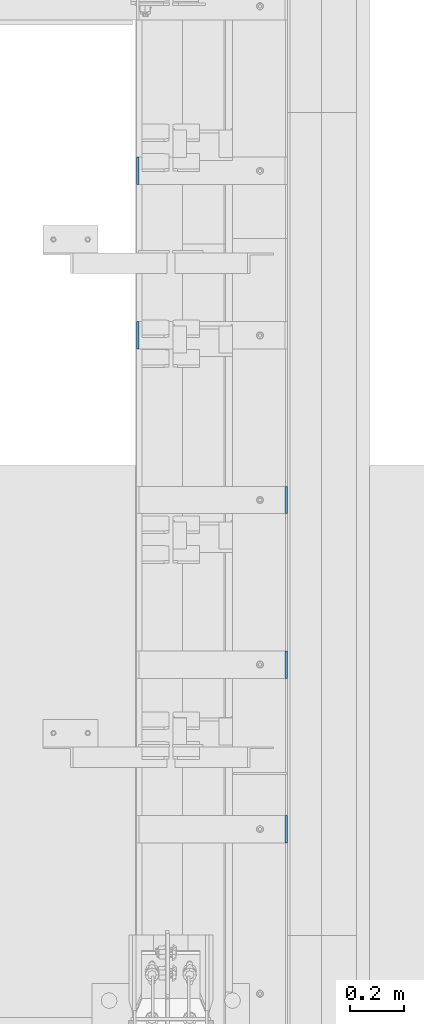
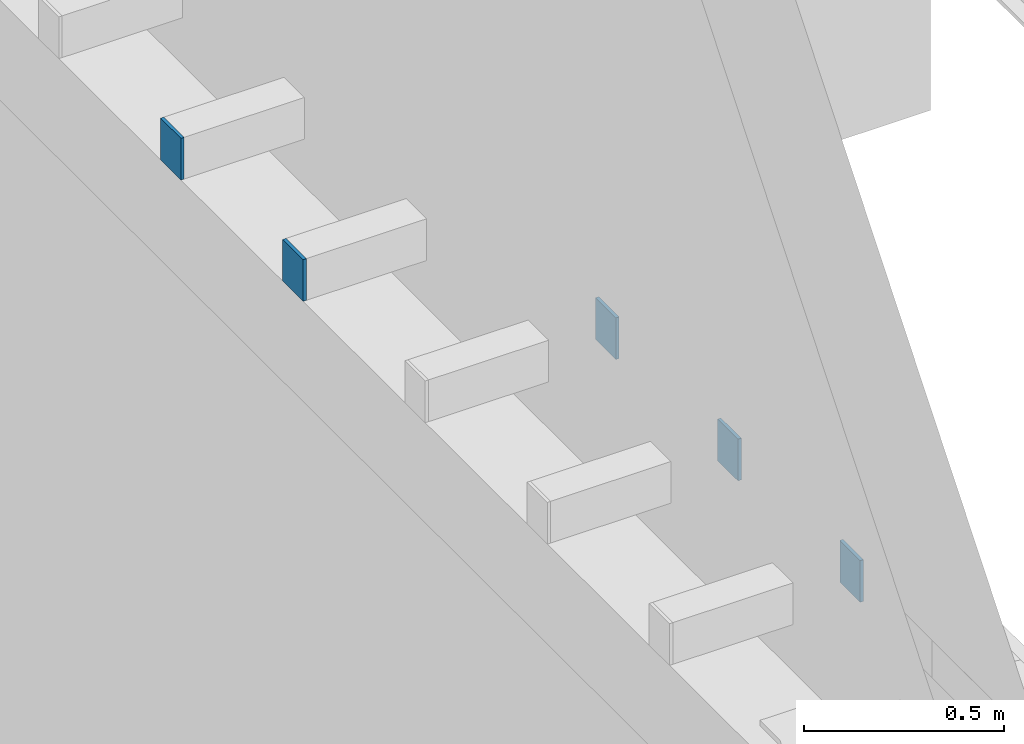
# One storey, part 448 of 1179: 5 columns, 5 elements without a shape of their own.
"""IFC2X3 building model written with IfcOpenShell, lengths in millimetres."""

from ifc_helpers import new_model, si_unit, frame, origin_with_axes, place, context, subcontext, project, spatial, faceted_brep, material, type_object, element, aggregate, save


model = new_model("IFC2X3")

# Units and contexts
model_context = context("Model", 3, precision=1e-05, world=origin_with_axes())
body_context = subcontext(model_context, "Body", "Model", "MODEL_VIEW")
ifc_project = project(units=[si_unit("LENGTHUNIT", "METRE", prefix="MILLI"), si_unit("AREAUNIT", "SQUARE_METRE"), si_unit("VOLUMEUNIT", "CUBIC_METRE"), si_unit("MASSUNIT", "GRAM", prefix="KILO"), si_unit("TIMEUNIT", "SECOND"), si_unit("PLANEANGLEUNIT", "RADIAN"), si_unit("SOLIDANGLEUNIT", "STERADIAN"), si_unit("THERMODYNAMICTEMPERATUREUNIT", "DEGREE_CELSIUS"), si_unit("LUMINOUSINTENSITYUNIT", "LUMEN")], contexts=[model_context])

# Site, building, storey
site_placement = place(None, origin_with_axes())
site = spatial("IfcSite", under=ifc_project, at=site_placement, CompositionType="ELEMENT")
building_placement = place(site_placement, origin_with_axes())
building = spatial("IfcBuilding", under=site, at=building_placement, Name="Undefined", CompositionType="ELEMENT")
storey_placement = place(building_placement, origin_with_axes())
storey = spatial("IfcBuildingStorey", under=building, at=storey_placement, Name="Undefined", CompositionType="ELEMENT", Elevation=0.0)

# Assembly, column
assembly_1_placement = place(storey_placement, origin_with_axes())
assembly_1 = element("IfcElementAssembly", 1, at=assembly_1_placement, inside=storey, Name="BEAM", AssemblyPlace="NOTDEFINED", PredefinedType="RIGID_FRAME")
ifc_material = material(Name="STEEL/A36")
column_type = type_object("IfcColumnType", PredefinedType="NOTDEFINED")
column_1_placement = place(assembly_1_placement, frame((24185.5625, 22529.8, 8013.69999998781), z_axis=(0.0, -1.0, 0.0), x_axis=(0.0, 0.0, 1.0)))
column_1 = element("IfcColumn", 2, at=column_1_placement, type_object=column_type, material=ifc_material, Name="PLATE", context=body_context, shape_type="Brep", body=[
    faceted_brep([(0.0, 4.76249999999982, -50.7999999999993), (0.0, 4.76249999999982, 50.7999999999993), (127.000000000371, 4.76249999928405, 50.8000000000002), (127.000000000371, 4.76249999928405, -50.8000000000002), (0.0, -4.76249999999982, 50.7999999999993), (127.0, -4.76250000000073, 50.7999999999993), (0.0, -4.76249999999982, -50.7999999999993), (127.0, -4.76250000000073, -50.7999999999993)], [[[0, 1, 2, 3]], [[1, 4, 5, 2]], [[4, 6, 7, 5]], [[6, 0, 3, 7]], [[5, 7, 3, 2]], [[6, 4, 1, 0]]]),
])
aggregate(assembly_1, [column_1])

assembly_2_placement = place(storey_placement, origin_with_axes())
assembly_2 = element("IfcElementAssembly", 3, at=assembly_2_placement, inside=storey, Name="BEAM", AssemblyPlace="NOTDEFINED", PredefinedType="RIGID_FRAME")
column_2_placement = place(assembly_2_placement, frame((24185.5625, 21920.2, 8013.69999998781), z_axis=(0.0, -1.0, 0.0), x_axis=(0.0, 0.0, 1.0)))
column_2 = element("IfcColumn", 4, at=column_2_placement, type_object=column_type, material=ifc_material, Name="PLATE", context=body_context, shape_type="Brep", body=[
    faceted_brep([(0.0, 4.76249999999982, -50.7999999999993), (0.0, 4.76249999999982, 50.7999999999993), (127.000000000371, 4.76249999928405, 50.8000000000002), (127.000000000371, 4.76249999928405, -50.8000000000002), (0.0, -4.76249999999982, 50.7999999999993), (127.0, -4.76250000000073, 50.7999999999993), (0.0, -4.76249999999982, -50.7999999999993), (127.0, -4.76250000000073, -50.7999999999993)], [[[0, 1, 2, 3]], [[1, 4, 5, 2]], [[4, 6, 7, 5]], [[6, 0, 3, 7]], [[5, 7, 3, 2]], [[6, 4, 1, 0]]]),
])
aggregate(assembly_2, [column_2])

assembly_3_placement = place(storey_placement, origin_with_axes())
assembly_3 = element("IfcElementAssembly", 5, at=assembly_3_placement, inside=storey, Name="BEAM", AssemblyPlace="NOTDEFINED", PredefinedType="RIGID_FRAME")
column_3_placement = place(assembly_3_placement, frame((24734.8375, 21310.6, 8013.69999998781), z_axis=(0.0, 1.0, 0.0), x_axis=(0.0, 0.0, 1.0)))
column_3 = element("IfcColumn", 6, at=column_3_placement, type_object=column_type, material=ifc_material, Name="PLATE", context=body_context, shape_type="Brep", body=[
    faceted_brep([(0.0, 4.76249999999982, -50.7999999999993), (0.0, 4.76249999999982, 50.7999999999993), (127.000000000371, 4.76249999928405, 50.8000000000002), (127.000000000371, 4.76249999928405, -50.8000000000002), (0.0, -4.76249999999982, 50.7999999999993), (127.0, -4.76250000000073, 50.7999999999993), (0.0, -4.76249999999982, -50.7999999999993), (127.0, -4.76250000000073, -50.7999999999993)], [[[0, 1, 2, 3]], [[1, 4, 5, 2]], [[4, 6, 7, 5]], [[6, 0, 3, 7]], [[5, 7, 3, 2]], [[6, 4, 1, 0]]]),
])
aggregate(assembly_3, [column_3])

assembly_4_placement = place(storey_placement, origin_with_axes())
assembly_4 = element("IfcElementAssembly", 7, at=assembly_4_placement, inside=storey, Name="BEAM", AssemblyPlace="NOTDEFINED", PredefinedType="RIGID_FRAME")
column_4_placement = place(assembly_4_placement, frame((24734.8375, 20701.0, 8013.69999998781), z_axis=(0.0, 1.0, 0.0), x_axis=(0.0, 0.0, 1.0)))
column_4 = element("IfcColumn", 8, at=column_4_placement, type_object=column_type, material=ifc_material, Name="PLATE", context=body_context, shape_type="Brep", body=[
    faceted_brep([(0.0, 4.76249999999982, -50.7999999999993), (0.0, 4.76249999999982, 50.7999999999993), (127.000000000371, 4.76249999928405, 50.8000000000002), (127.000000000371, 4.76249999928405, -50.8000000000002), (0.0, -4.76249999999982, 50.7999999999993), (127.0, -4.76250000000073, 50.7999999999993), (0.0, -4.76249999999982, -50.7999999999993), (127.0, -4.76250000000073, -50.7999999999993)], [[[0, 1, 2, 3]], [[1, 4, 5, 2]], [[4, 6, 7, 5]], [[6, 0, 3, 7]], [[5, 7, 3, 2]], [[6, 4, 1, 0]]]),
])
aggregate(assembly_4, [column_4])

assembly_5_placement = place(storey_placement, origin_with_axes())
assembly_5 = element("IfcElementAssembly", 9, at=assembly_5_placement, inside=storey, Name="BEAM", AssemblyPlace="NOTDEFINED", PredefinedType="RIGID_FRAME")
column_5_placement = place(assembly_5_placement, frame((24734.8375, 20091.4, 8013.69999998781), z_axis=(0.0, 1.0, 0.0), x_axis=(0.0, 0.0, 1.0)))
column_5 = element("IfcColumn", 10, at=column_5_placement, type_object=column_type, material=ifc_material, Name="PLATE", context=body_context, shape_type="Brep", body=[
    faceted_brep([(0.0, 4.76249999999982, -50.7999999999993), (0.0, 4.76249999999982, 50.7999999999993), (127.000000000371, 4.76249999928405, 50.8000000000002), (127.000000000371, 4.76249999928405, -50.8000000000002), (0.0, -4.76249999999982, 50.7999999999993), (127.0, -4.76250000000073, 50.7999999999993), (0.0, -4.76249999999982, -50.7999999999993), (127.0, -4.76250000000073, -50.7999999999993)], [[[0, 1, 2, 3]], [[1, 4, 5, 2]], [[4, 6, 7, 5]], [[6, 0, 3, 7]], [[5, 7, 3, 2]], [[6, 4, 1, 0]]]),
])
aggregate(assembly_5, [column_5])

save(model, "model.ifc")
